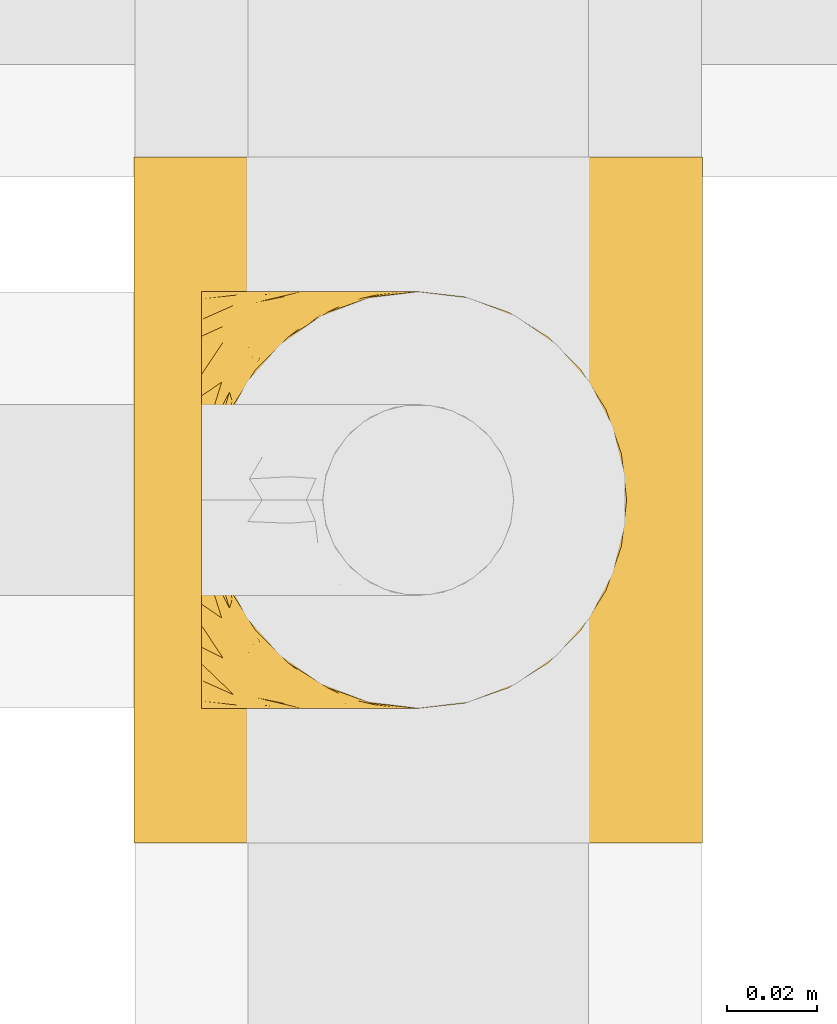
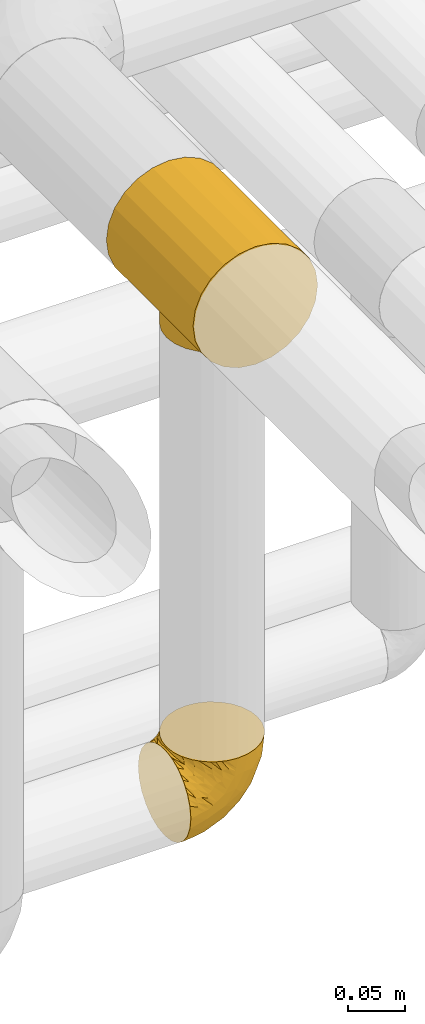
# One storey, part 350 of 827: 2 coverings.
"""IFC2X3 building model written with IfcOpenShell, lengths in millimetres."""

from ifc_helpers import new_model, entity, si_unit, converted_unit, derived_unit, direction, frame, origin, place, context, subcontext, project, spatial, faceted_brep, element, save


model = new_model("IFC2X3")

# Units and contexts
model_context = context("Model", 3, precision=0.01, world=origin(), true_north=direction((6.12303176911189e-17, 1.0)))
body_context = subcontext(model_context, "Body", "Model", "MODEL_VIEW")
ifc_project = project(units=[si_unit("LENGTHUNIT", "METRE", prefix="MILLI"), si_unit("AREAUNIT", "SQUARE_METRE"), si_unit("VOLUMEUNIT", "CUBIC_METRE"), converted_unit("PLANEANGLEUNIT", "DEGREE", entity("IfcRatioMeasure", 0.0174532925199433), si_unit("PLANEANGLEUNIT", "RADIAN"), dimensions=[0, 0, 0, 0, 0, 0, 0]), si_unit("MASSUNIT", "GRAM", prefix="KILO"), derived_unit("MASSDENSITYUNIT", [(si_unit("MASSUNIT", "GRAM", prefix="KILO"), 1), (si_unit("LENGTHUNIT", "METRE"), -3)]), derived_unit("MOMENTOFINERTIAUNIT", [(si_unit("LENGTHUNIT", "METRE"), 4)]), si_unit("TIMEUNIT", "SECOND"), si_unit("FREQUENCYUNIT", "HERTZ"), si_unit("THERMODYNAMICTEMPERATUREUNIT", "DEGREE_CELSIUS"), derived_unit("THERMALTRANSMITTANCEUNIT", [(si_unit("MASSUNIT", "GRAM", prefix="KILO"), 1), (si_unit("THERMODYNAMICTEMPERATUREUNIT", "KELVIN"), -1), (si_unit("TIMEUNIT", "SECOND"), -3)]), derived_unit("VOLUMETRICFLOWRATEUNIT", [(si_unit("LENGTHUNIT", "METRE"), 3), (si_unit("TIMEUNIT", "SECOND"), -1)]), derived_unit("MASSFLOWRATEUNIT", [(si_unit("MASSUNIT", "GRAM", prefix="KILO"), 1), (si_unit("TIMEUNIT", "SECOND"), -1)]), derived_unit("ROTATIONALFREQUENCYUNIT", [(si_unit("TIMEUNIT", "SECOND"), -1)]), si_unit("ELECTRICCURRENTUNIT", "AMPERE"), si_unit("ELECTRICVOLTAGEUNIT", "VOLT"), si_unit("POWERUNIT", "WATT"), si_unit("FORCEUNIT", "NEWTON", prefix="KILO"), si_unit("ILLUMINANCEUNIT", "LUX"), si_unit("LUMINOUSFLUXUNIT", "LUMEN"), si_unit("LUMINOUSINTENSITYUNIT", "CANDELA"), derived_unit("USERDEFINED", [(si_unit("MASSUNIT", "GRAM", prefix="KILO"), -1), (si_unit("LENGTHUNIT", "METRE"), -2), (si_unit("TIMEUNIT", "SECOND"), 3), (si_unit("LUMINOUSFLUXUNIT", "LUMEN"), 1)]), derived_unit("LINEARVELOCITYUNIT", [(si_unit("LENGTHUNIT", "METRE"), 1), (si_unit("TIMEUNIT", "SECOND"), -1)]), si_unit("PRESSUREUNIT", "PASCAL"), derived_unit("USERDEFINED", [(si_unit("LENGTHUNIT", "METRE"), -2), (si_unit("MASSUNIT", "GRAM", prefix="KILO"), 1), (si_unit("TIMEUNIT", "SECOND"), -2)]), derived_unit("LINEARFORCEUNIT", [(si_unit("MASSUNIT", "GRAM", prefix="KILO"), 1), (si_unit("LENGTHUNIT", "METRE"), 1), (si_unit("TIMEUNIT", "SECOND"), -2), (si_unit("LENGTHUNIT", "METRE"), -1)]), derived_unit("PLANARFORCEUNIT", [(si_unit("MASSUNIT", "GRAM", prefix="KILO"), 1), (si_unit("LENGTHUNIT", "METRE"), 1), (si_unit("TIMEUNIT", "SECOND"), -2), (si_unit("LENGTHUNIT", "METRE"), -2)])], contexts=[model_context])

# Site, building, storey
site_placement = place(None, origin())
site = spatial("IfcSite", under=ifc_project, at=site_placement, CompositionType="ELEMENT")
building_placement = place(site_placement, origin())
building = spatial("IfcBuilding", under=site, at=building_placement, CompositionType="ELEMENT")
storey_placement = place(building_placement, frame((0.0, 0.0, 28200.0)))
storey = spatial("IfcBuildingStorey", under=building, at=storey_placement, Name="08", CompositionType="ELEMENT", Elevation=28200.0)

# Coverings
covering_1_placement = place(storey_placement, frame((36155.39, 18148.95, 3485.35)))
element("IfcCovering", 1, at=covering_1_placement, inside=storey, Name=":ADSK_", ObjectType=":ADSK_", PredefinedType="INSULATION", context=body_context, shape_type="Brep", body=[
    faceted_brep([(33.12, 152.0, 119.25), (48.33, 152.0, 125.55), (64.65, 152.0, 127.7), (80.96, 152.0, 125.55), (96.17, 152.0, 119.25), (109.23, 152.0, 109.23), (119.25, 152.0, 96.17), (125.55, 152.0, 80.96), (127.7, 152.0, 64.65), (125.55, 152.0, 48.33), (119.25, 152.0, 33.12), (109.23, 152.0, 20.06), (102.7, 152.0, 15.05), (96.17, 152.0, 10.04), (88.57, 152.0, 6.89), (80.96, 152.0, 3.74), (72.8, 152.0, 2.67), (64.65, 152.0, 1.6), (56.49, 152.0, 2.67), (48.33, 152.0, 3.74), (40.72, 152.0, 6.89), (33.12, 152.0, 10.04), (26.59, 152.0, 15.05), (20.06, 152.0, 20.06), (10.04, 152.0, 33.12), (3.74, 152.0, 48.33), (1.6, 152.0, 64.65), (3.74, 152.0, 80.96), (10.04, 152.0, 96.17), (20.06, 152.0, 109.23), (127.7, 0.0, 64.65), (125.55, 0.0, 80.96), (119.25, 0.0, 96.17), (109.23, 0.0, 109.23), (96.17, 0.0, 119.25), (80.96, 0.0, 125.55), (64.65, 0.0, 127.7), (48.33, 0.0, 125.55), (33.12, 0.0, 119.25), (20.06, 0.0, 109.23), (10.04, 0.0, 96.17), (3.74, 0.0, 80.96), (1.6, 0.0, 64.65), (3.74, 0.0, 48.33), (10.04, 0.0, 33.12), (20.06, 0.0, 20.06), (26.59, 0.0, 15.05), (33.12, 0.0, 10.04), (40.72, 0.0, 6.89), (48.33, 0.0, 3.74), (56.49, 0.0, 2.67), (64.65, 0.0, 1.6), (72.8, 0.0, 2.67), (80.96, 0.0, 3.74), (88.57, 0.0, 6.89), (96.17, 0.0, 10.04), (102.7, 0.0, 15.05), (109.23, 0.0, 20.06), (119.25, 0.0, 33.12), (125.55, 0.0, 48.33), (106.13, 55.66, 17.16), (100.79, 47.22, 12.98), (85.23, 117.36, 5.05), (109.6, 65.36, 20.44), (110.85, 76.0, 21.74), (109.6, 86.64, 20.44), (70.0, 121.57, 2.05), (68.66, 121.73, 1.94), (67.32, 121.89, 1.82), (65.98, 122.04, 1.71), (64.65, 122.2, 1.6), (64.65, 29.8, 1.6), (65.98, 29.96, 1.71), (67.32, 30.11, 1.82), (68.66, 30.27, 1.94), (70.0, 30.43, 2.05), (106.13, 96.34, 17.16), (100.79, 104.78, 12.98), (85.23, 34.64, 5.05), (89.51, 37.39, 6.89), (93.79, 40.15, 8.73), (80.29, 119.15, 3.78), (77.82, 120.05, 3.15), (75.35, 120.94, 2.51), (75.35, 31.06, 2.51), (72.67, 30.74, 2.28), (77.82, 31.95, 3.15), (80.29, 32.85, 3.78), (93.79, 111.85, 8.73), (89.51, 114.61, 6.89), (72.67, 121.26, 2.28), (59.29, 30.43, 2.05), (53.94, 31.06, 2.51), (35.5, 40.15, 8.73), (39.78, 37.39, 6.89), (44.06, 34.64, 5.05), (49.0, 32.85, 3.78), (51.47, 31.95, 3.15), (56.62, 30.74, 2.28), (59.29, 121.57, 2.05), (56.62, 121.26, 2.28), (53.94, 120.94, 2.51), (63.31, 122.04, 1.71), (61.97, 121.89, 1.82), (60.63, 121.73, 1.94), (60.63, 30.27, 1.94), (61.97, 30.11, 1.82), (63.31, 29.96, 1.71), (35.5, 111.85, 8.73), (44.06, 117.36, 5.05), (28.5, 104.78, 12.98), (51.47, 120.05, 3.15), (49.0, 119.15, 3.78), (28.5, 47.22, 12.98), (23.17, 55.66, 17.16), (19.69, 65.36, 20.44), (18.45, 76.0, 21.74), (23.17, 96.34, 17.16), (19.69, 86.64, 20.44), (39.78, 114.61, 6.89), (110.85, 76.0, 0.65), (109.27, 64.04, 0.65), (104.66, 52.9, 0.65), (97.31, 43.33, 0.65), (87.75, 35.99, 0.65), (82.17, 33.68, 0.65), (79.39, 32.53, 0.65), (76.6, 31.37, 0.65), (75.11, 31.18, 0.65), (73.61, 30.98, 0.65), (72.12, 30.78, 0.65), (70.62, 30.59, 0.65), (69.13, 30.39, 0.65), (67.63, 30.19, 0.65), (66.14, 30.0, 0.65), (64.65, 29.8, 0.65), (63.15, 30.0, 0.65), (61.66, 30.19, 0.65), (60.16, 30.39, 0.65), (58.67, 30.59, 0.65), (57.17, 30.78, 0.65), (55.68, 30.98, 0.65), (54.18, 31.18, 0.65), (52.69, 31.37, 0.65), (49.9, 32.53, 0.65), (47.12, 33.68, 0.65), (41.55, 35.99, 0.65), (31.98, 43.33, 0.65), (24.63, 52.9, 0.65), (20.02, 64.04, 0.65), (18.45, 76.0, 0.65), (20.02, 87.96, 0.65), (24.63, 99.1, 0.65), (31.98, 108.67, 0.65), (41.55, 116.01, 0.65), (47.12, 118.32, 0.65), (49.9, 119.47, 0.65), (52.69, 120.63, 0.65), (54.18, 120.82, 0.65), (55.68, 121.02, 0.65), (57.17, 121.22, 0.65), (58.67, 121.41, 0.65), (60.16, 121.61, 0.65), (61.66, 121.81, 0.65), (63.15, 122.0, 0.65), (64.65, 122.2, 0.65), (66.14, 122.0, 0.65), (67.63, 121.81, 0.65), (69.13, 121.61, 0.65), (70.62, 121.41, 0.65), (72.12, 121.22, 0.65), (73.61, 121.02, 0.65), (75.11, 120.82, 0.65), (76.6, 120.63, 0.65), (79.39, 119.47, 0.65), (82.17, 118.32, 0.65), (87.75, 116.01, 0.65), (97.31, 108.67, 0.65), (104.66, 99.1, 0.65), (109.27, 87.96, 0.65)], [[[0, 1, 2, 3, 4, 5, 6, 7, 8, 9, 10, 11, 12, 13, 14, 15, 16, 17, 18, 19, 20, 21, 22, 23, 24, 25, 26, 27, 28, 29]], [[30, 31, 32, 33, 34, 35, 36, 37, 38, 39, 40, 41, 42, 43, 44, 45, 46, 47, 48, 49, 50, 51, 52, 53, 54, 55, 56, 57, 58, 59]], [[34, 33, 5, 4]], [[2, 36, 35, 3]], [[4, 3, 35, 34]], [[6, 32, 31, 7]], [[7, 31, 30, 8]], [[5, 33, 32, 6]], [[59, 9, 8, 30]], [[58, 10, 9, 59]], [[56, 60, 57]], [[61, 56, 55]], [[62, 15, 14]], [[60, 63, 57]], [[60, 56, 61]], [[58, 57, 64]], [[57, 63, 64]], [[64, 65, 11]], [[17, 66, 67, 68, 69, 70]], [[51, 71, 72, 73, 74, 75]], [[12, 76, 77]], [[76, 11, 65]], [[77, 13, 12]], [[64, 11, 10]], [[64, 10, 58]], [[54, 78, 79, 80]], [[54, 80, 55]], [[78, 54, 53]], [[15, 62, 81, 82, 83]], [[84, 53, 52]], [[51, 75, 52]], [[52, 75, 85, 84]], [[53, 84, 86, 87, 78]], [[77, 88, 13]], [[88, 14, 13]], [[14, 88, 89, 62]], [[16, 83, 90, 66]], [[12, 11, 76]], [[17, 16, 66]], [[16, 15, 83]], [[80, 61, 55]], [[50, 91, 51]], [[92, 50, 49]], [[47, 93, 48]], [[48, 93, 94, 95]], [[95, 49, 48]], [[49, 95, 96, 97, 92]], [[50, 92, 98, 91]], [[18, 99, 100, 101]], [[17, 70, 102, 103, 104, 99]], [[51, 91, 105, 106, 107, 71]], [[108, 21, 20]], [[17, 99, 18]], [[20, 19, 109]], [[21, 108, 110]], [[109, 19, 101, 111, 112]], [[113, 47, 46]], [[113, 93, 47]], [[46, 114, 113]], [[114, 46, 45]], [[114, 45, 115]], [[24, 44, 43, 25]], [[44, 116, 45]], [[45, 116, 115]], [[43, 42, 26, 25]], [[101, 19, 18]], [[117, 118, 23]], [[20, 109, 119, 108]], [[110, 22, 21]], [[22, 117, 23]], [[118, 116, 23]], [[116, 24, 23]], [[116, 44, 24]], [[117, 22, 110]], [[27, 41, 40, 28]], [[28, 40, 39, 29]], [[42, 41, 27, 26]], [[0, 38, 37, 1]], [[1, 37, 36, 2]], [[29, 39, 38, 0]], [[120, 121, 122, 123, 124, 125, 126, 127, 128, 129, 130, 131, 132, 133, 134, 135, 136, 137, 138, 139, 140, 141, 142, 143, 144, 145, 146, 147, 148, 149, 150, 151, 152, 153, 154, 155, 156, 157, 158, 159, 160, 161, 162, 163, 164, 165, 166, 167, 168, 169, 170, 171, 172, 173, 174, 175, 176, 177, 178, 179]], [[84, 129, 128, 127]], [[132, 75, 74]], [[74, 133, 132]], [[78, 125, 124]], [[73, 134, 133]], [[132, 131, 75]], [[127, 86, 84]], [[79, 78, 124]], [[86, 126, 87]], [[123, 79, 124]], [[123, 80, 79]], [[87, 126, 125]], [[61, 123, 122]], [[85, 131, 130, 129]], [[122, 121, 60]], [[129, 84, 85]], [[72, 135, 134]], [[120, 63, 121]], [[125, 78, 87]], [[61, 122, 60]], [[86, 127, 126]], [[63, 60, 121]], [[64, 63, 120]], [[131, 85, 75]], [[123, 61, 80]], [[133, 74, 73]], [[135, 72, 71]], [[134, 73, 72]], [[65, 120, 179]], [[69, 165, 70]], [[90, 171, 170, 169]], [[76, 179, 178]], [[173, 83, 82]], [[64, 120, 65]], [[176, 62, 89]], [[65, 179, 76]], [[178, 77, 76]], [[83, 173, 172, 171]], [[178, 177, 77]], [[167, 67, 168]], [[177, 176, 89]], [[167, 68, 67]], [[175, 174, 81]], [[81, 174, 82]], [[67, 66, 168]], [[169, 66, 90]], [[88, 177, 89]], [[62, 176, 175]], [[171, 90, 83]], [[175, 81, 62]], [[82, 174, 173]], [[166, 69, 68]], [[177, 88, 77]], [[66, 169, 168]], [[68, 167, 166]], [[165, 69, 166]], [[101, 159, 158, 157]], [[162, 99, 104]], [[104, 163, 162]], [[109, 155, 154]], [[103, 164, 163]], [[162, 161, 99]], [[157, 111, 101]], [[119, 109, 154]], [[111, 156, 112]], [[153, 119, 154]], [[153, 108, 119]], [[112, 156, 155]], [[110, 153, 152]], [[100, 161, 160, 159]], [[152, 151, 117]], [[159, 101, 100]], [[102, 165, 164]], [[150, 118, 151]], [[155, 109, 112]], [[110, 152, 117]], [[111, 157, 156]], [[118, 117, 151]], [[116, 118, 150]], [[161, 100, 99]], [[153, 110, 108]], [[163, 104, 103]], [[165, 102, 70]], [[164, 103, 102]], [[115, 150, 149]], [[107, 135, 71]], [[98, 141, 140, 139]], [[114, 149, 148]], [[143, 92, 97]], [[116, 150, 115]], [[146, 95, 94]], [[115, 149, 114]], [[148, 113, 114]], [[92, 143, 142, 141]], [[148, 147, 113]], [[137, 105, 138]], [[147, 146, 94]], [[137, 106, 105]], [[145, 144, 96]], [[96, 144, 97]], [[105, 91, 138]], [[139, 91, 98]], [[93, 147, 94]], [[95, 146, 145]], [[141, 98, 92]], [[145, 96, 95]], [[97, 144, 143]], [[136, 107, 106]], [[147, 93, 113]], [[91, 139, 138]], [[106, 137, 136]], [[135, 107, 136]]]),
])
covering_2_placement = place(storey_placement, frame((36170.44, 18177.15, 2952.11)))
element("IfcCovering", 2, at=covering_2_placement, inside=storey, Name=":ADSK_", ObjectType=":ADSK_", PredefinedType="INSULATION", context=body_context, shape_type="Brep", body=[
    faceted_brep([(78.41, 11.68, 95.8), (85.72, 19.0, 95.8), (91.22, 27.76, 95.8), (94.64, 37.52, 95.8), (95.8, 47.8, 95.8), (94.64, 58.08, 95.8), (91.22, 67.85, 95.8), (85.71, 76.61, 95.8), (78.39, 83.92, 95.8), (69.63, 89.42, 95.8), (59.87, 92.84, 95.8), (49.6, 94.0, 95.8), (45.45, 93.53, 95.8), (42.38, 93.18, 95.8), (39.31, 92.84, 95.8), (34.43, 91.13, 95.8), (29.54, 89.42, 95.8), (25.16, 86.66, 95.8), (20.78, 83.91, 95.8), (17.13, 80.25, 95.8), (13.47, 76.59, 95.8), (7.97, 67.83, 95.8), (6.26, 62.95, 95.8), (4.55, 58.07, 95.8), (3.4, 47.8, 95.8), (4.55, 37.51, 95.8), (6.26, 32.63, 95.8), (7.97, 27.74, 95.8), (13.48, 18.98, 95.8), (17.14, 15.33, 95.8), (20.8, 11.67, 95.8), (25.18, 8.92, 95.8), (29.56, 6.17, 95.8), (34.44, 4.46, 95.8), (39.32, 2.75, 95.8), (42.39, 2.41, 95.8), (45.45, 2.06, 95.8), (49.6, 1.6, 95.8), (59.88, 2.75, 95.8), (69.65, 6.17, 95.8), (1.6, 47.8, 94.0), (1.6, 59.75, 92.42), (1.6, 70.9, 87.81), (1.6, 75.68, 84.13), (1.6, 80.46, 80.46), (1.6, 84.13, 75.68), (1.6, 87.81, 70.9), (1.6, 90.11, 65.32), (1.6, 92.42, 59.75), (1.6, 92.9, 56.14), (1.6, 93.17, 54.06), (1.6, 93.45, 51.97), (1.6, 94.0, 47.8), (1.6, 92.42, 35.84), (1.6, 87.81, 24.7), (1.6, 80.46, 15.13), (1.6, 70.9, 7.78), (1.6, 59.75, 3.17), (1.6, 47.8, 1.6), (1.6, 35.84, 3.17), (1.6, 24.7, 7.78), (1.6, 15.13, 15.13), (1.6, 7.78, 24.7), (1.6, 3.17, 35.84), (1.6, 1.6, 47.8), (1.6, 2.14, 51.97), (1.6, 2.69, 56.14), (1.6, 3.17, 59.75), (1.6, 5.48, 65.32), (1.6, 7.78, 70.9), (1.6, 11.46, 75.68), (1.6, 15.13, 80.46), (1.6, 19.91, 84.13), (1.6, 24.7, 87.81), (1.6, 35.84, 92.42), (36.81, 23.61, 15.84), (23.28, 31.99, 6.99), (45.8, 35.87, 14.39), (30.7, 47.8, 6.21), (21.2, 40.43, 4.26), (12.96, 47.8, 3.39), (66.19, 31.83, 31.2), (54.51, 23.37, 26.47), (17.98, 21.41, 11.44), (36.69, 3.07, 47.66), (35.54, 1.6, 61.85), (31.64, 1.6, 59.25), (27.75, 1.6, 56.65), (23.86, 1.6, 54.05), (19.96, 1.6, 51.45), (22.8, 13.45, 19.8), (42.67, 15.25, 26.22), (33.21, 8.07, 31.58), (59.45, 16.0, 38.36), (71.5, 17.34, 51.54), (62.66, 10.58, 51.6), (54.5, 5.34, 55.97), (47.57, 2.39, 62.88), (48.81, 8.36, 41.35), (74.98, 10.04, 82.24), (18.7, 2.59, 40.88), (15.75, 6.28, 29.0), (91.17, 34.28, 74.06), (85.28, 38.73, 54.53), (82.58, 27.25, 57.98), (75.78, 29.88, 43.81), (74.98, 38.6, 38.22), (67.27, 23.44, 38.33), (87.38, 25.25, 74.76), (82.04, 17.23, 76.85), (94.0, 47.8, 84.43), (77.8, 47.8, 40.43), (67.38, 47.8, 30.01), (56.2, 2.53, 78.67), (48.85, 1.6, 92.06), (48.11, 1.6, 88.32), (47.57, 1.6, 85.6), (47.03, 1.6, 82.88), (46.48, 1.6, 80.15), (45.94, 1.6, 77.43), (65.78, 5.71, 76.36), (17.24, 1.6, 50.91), (14.51, 1.6, 50.37), (11.79, 1.6, 49.82), (9.07, 1.6, 49.28), (7.2, 1.6, 48.91), (5.33, 1.6, 48.54), (91.18, 47.8, 66.69), (43.34, 1.6, 73.53), (40.74, 1.6, 69.64), (38.14, 1.6, 65.75), (72.73, 11.89, 66.13), (56.96, 47.8, 19.59), (62.23, 39.69, 24.64), (84.49, 47.8, 53.56), (43.83, 47.8, 12.9), (12.05, 13.84, 82.81), (18.95, 9.16, 81.22), (13.02, 15.79, 86.57), (8.34, 25.75, 92.75), (14.63, 16.09, 89.68), (11.09, 7.51, 72.26), (13.66, 3.99, 64.73), (20.08, 2.66, 62.45), (9.61, 3.16, 60.63), (9.48, 2.35, 56.91), (16.1, 2.23, 58.14), (3.42, 38.35, 93.7), (26.63, 6.18, 83.4), (33.72, 2.7, 75.54), (34.77, 2.93, 79.46), (6.75, 16.01, 82.28), (13.31, 9.08, 76.25), (21.11, 9.3, 84.69), (19.94, 11.68, 90.18), (8.67, 4.65, 65.12), (26.11, 3.65, 71.71), (29.3, 3.61, 75.21), (6.32, 12.8, 78.6), (39.92, 2.43, 87.27), (27.05, 6.83, 87.92), (6.04, 21.65, 86.94), (34.4, 3.7, 86.1), (2.87, 47.8, 94.52), (20.92, 3.37, 66.23), (27.43, 7.03, 91.08), (7.54, 7.87, 71.77), (18.45, 7.26, 76.21), (23.88, 3.41, 68.59), (7.77, 23.81, 89.94), (13.3, 86.5, 76.25), (11.09, 88.08, 72.26), (6.33, 82.79, 78.6), (9.07, 94.0, 49.28), (5.33, 94.0, 48.54), (14.51, 94.0, 50.37), (11.79, 94.0, 49.82), (3.42, 57.24, 93.7), (7.76, 71.76, 89.95), (47.03, 94.0, 82.88), (47.57, 94.0, 85.6), (48.85, 94.0, 92.06), (48.11, 94.0, 88.32), (14.62, 79.49, 89.68), (27.03, 88.75, 87.92), (20.08, 92.93, 62.45), (20.92, 92.22, 66.24), (27.75, 94.0, 56.65), (31.64, 94.0, 59.25), (9.61, 92.43, 60.63), (9.48, 93.24, 56.91), (8.33, 69.82, 92.76), (6.74, 79.57, 82.28), (12.04, 81.74, 82.81), (23.86, 94.0, 54.05), (19.96, 94.0, 51.45), (16.1, 93.36, 58.14), (19.93, 83.9, 90.18), (21.1, 86.28, 84.7), (39.92, 93.16, 87.25), (33.68, 92.88, 75.58), (29.28, 91.98, 75.2), (26.62, 89.41, 83.39), (26.08, 91.93, 71.7), (18.93, 86.42, 81.22), (27.87, 88.82, 90.73), (34.75, 92.66, 79.47), (6.04, 73.93, 86.94), (38.14, 94.0, 65.75), (12.79, 79.5, 86.75), (34.41, 91.89, 86.08), (45.94, 94.0, 77.43), (43.34, 94.0, 73.53), (40.74, 94.0, 69.64), (13.66, 91.6, 64.73), (17.24, 94.0, 50.91), (8.67, 90.94, 65.12), (35.54, 94.0, 61.85), (23.83, 92.16, 68.62), (18.43, 88.32, 76.22), (6.03, 86.13, 74.03), (46.48, 94.0, 80.15), (34.52, 93.2, 49.81), (21.2, 55.16, 4.26), (23.82, 82.02, 19.95), (41.32, 84.29, 30.61), (47.62, 76.94, 25.71), (52.66, 68.33, 22.43), (36.81, 71.98, 15.85), (49.75, 92.52, 60.69), (19.07, 92.9, 40.49), (45.8, 59.72, 14.39), (23.28, 63.6, 6.99), (21.35, 88.89, 29.56), (17.98, 74.18, 11.45), (82.57, 68.35, 57.98), (91.17, 61.33, 74.06), (85.27, 56.86, 54.52), (73.89, 68.62, 43.47), (66.19, 63.76, 31.2), (62.43, 72.19, 33.27), (63.53, 88.69, 64.26), (58.45, 92.19, 74.29), (67.16, 89.75, 80.41), (62.22, 55.9, 24.64), (81.54, 77.99, 73.62), (74.8, 85.21, 78.98), (75.83, 74.99, 53.69), (41.45, 90.23, 42.86), (76.72, 59.86, 41.67), (88.2, 70.75, 79.66), (71.6, 81.72, 58.41), (56.23, 86.53, 47.11), (59.44, 79.6, 38.37)], [[[0, 1, 2, 3, 4, 5, 6, 7, 8, 9, 10, 11, 12, 13, 14, 15, 16, 17, 18, 19, 20, 21, 22, 23, 24, 25, 26, 27, 28, 29, 30, 31, 32, 33, 34, 35, 36, 37, 38, 39]], [[40, 41, 42, 43, 44, 45, 46, 47, 48, 49, 50, 51, 52, 53, 54, 55, 56, 57, 58, 59, 60, 61, 62, 63, 64, 65, 66, 67, 68, 69, 70, 71, 72, 73, 74]], [[75, 76, 77]], [[78, 79, 80]], [[77, 81, 82]], [[76, 75, 83]], [[84, 85, 86, 87, 88, 89]], [[90, 91, 92]], [[76, 60, 59]], [[93, 94, 95]], [[90, 62, 61]], [[83, 61, 60]], [[96, 97, 84]], [[98, 93, 95]], [[0, 39, 99]], [[100, 84, 89]], [[62, 101, 63]], [[2, 102, 3]], [[92, 84, 100]], [[103, 102, 104]], [[103, 105, 106]], [[93, 107, 94]], [[1, 108, 2]], [[92, 101, 90]], [[108, 1, 109]], [[102, 110, 3]], [[93, 82, 107]], [[102, 108, 104]], [[111, 106, 112]], [[109, 0, 99]], [[113, 37, 114, 115, 116, 117, 118, 119]], [[120, 38, 113]], [[100, 89, 121, 122, 123, 124, 125, 126, 64]], [[127, 102, 103]], [[97, 119, 128, 129, 130, 85]], [[99, 120, 131]], [[132, 133, 77]], [[59, 80, 79]], [[1, 0, 109]], [[98, 84, 92]], [[94, 109, 131]], [[120, 39, 38]], [[93, 91, 82]], [[104, 94, 105]], [[97, 113, 119]], [[95, 120, 96]], [[83, 90, 61]], [[91, 93, 98]], [[64, 63, 100]], [[100, 63, 101]], [[77, 76, 79]], [[133, 106, 81]], [[84, 97, 85]], [[113, 96, 120]], [[113, 97, 96]], [[37, 113, 38]], [[110, 102, 127]], [[110, 4, 3]], [[103, 111, 134, 127]], [[90, 75, 91]], [[82, 81, 107]], [[91, 75, 82]], [[77, 82, 75]], [[76, 83, 60]], [[90, 83, 75]], [[105, 107, 81]], [[94, 131, 95]], [[105, 94, 107]], [[109, 94, 104]], [[120, 95, 131]], [[98, 95, 96]], [[84, 98, 96]], [[98, 92, 91]], [[106, 105, 81]], [[103, 104, 105]], [[112, 106, 133]], [[103, 106, 111]], [[112, 133, 132]], [[81, 77, 133]], [[77, 78, 135, 132]], [[120, 99, 39]], [[109, 99, 131]], [[59, 58, 80]], [[59, 79, 76]], [[90, 101, 62]], [[100, 101, 92]], [[2, 108, 102]], [[109, 104, 108]], [[78, 77, 79]], [[136, 137, 138]], [[27, 139, 140]], [[141, 142, 143]], [[144, 145, 121]], [[146, 89, 88]], [[147, 139, 25]], [[148, 149, 150]], [[136, 151, 152]], [[147, 40, 74]], [[24, 147, 25]], [[140, 153, 154]], [[33, 116, 34]], [[73, 72, 151]], [[114, 37, 36, 35, 34, 116, 115]], [[146, 155, 144]], [[156, 85, 130]], [[157, 149, 148]], [[151, 158, 152]], [[117, 33, 159]], [[29, 154, 160]], [[161, 74, 73]], [[162, 128, 119]], [[66, 65, 64, 126, 125, 124, 123, 122, 67]], [[163, 147, 24]], [[27, 140, 28]], [[149, 129, 150]], [[139, 27, 26, 25]], [[68, 144, 69]], [[129, 128, 150]], [[164, 87, 86]], [[130, 129, 149]], [[122, 145, 67]], [[154, 153, 148]], [[162, 119, 159]], [[165, 30, 160]], [[150, 160, 148]], [[128, 162, 150]], [[30, 165, 31]], [[145, 144, 68]], [[89, 146, 144]], [[87, 164, 143]], [[166, 155, 142]], [[88, 87, 143]], [[162, 160, 150]], [[160, 30, 29]], [[154, 29, 28]], [[140, 154, 28]], [[160, 154, 148]], [[140, 137, 153]], [[157, 148, 153]], [[156, 130, 157]], [[153, 137, 157]], [[157, 137, 156]], [[167, 137, 136]], [[168, 85, 156]], [[152, 168, 167]], [[167, 168, 156]], [[164, 152, 141]], [[71, 158, 72]], [[152, 167, 136]], [[88, 142, 146]], [[144, 155, 69]], [[146, 142, 155]], [[70, 166, 71]], [[142, 141, 166]], [[70, 69, 155]], [[141, 158, 71]], [[161, 73, 151]], [[138, 137, 140]], [[161, 136, 169]], [[136, 161, 151]], [[74, 161, 169]], [[152, 158, 141]], [[151, 72, 158]], [[168, 152, 164]], [[137, 167, 156]], [[164, 86, 168]], [[85, 168, 86]], [[116, 33, 117]], [[130, 149, 157]], [[67, 145, 68]], [[121, 89, 144]], [[145, 122, 121]], [[40, 147, 163]], [[169, 147, 74]], [[159, 33, 32]], [[162, 159, 32]], [[159, 119, 118, 117]], [[139, 147, 169]], [[139, 169, 138]], [[162, 32, 31]], [[141, 143, 164]], [[88, 143, 142]], [[71, 166, 141]], [[155, 166, 70]], [[139, 138, 140]], [[169, 136, 138]], [[160, 162, 165]], [[162, 31, 165]], [[170, 171, 172]], [[173, 174, 52, 51, 50, 49, 48, 175, 176]], [[177, 178, 41]], [[179, 15, 180]], [[12, 11, 181, 182, 180, 14, 13]], [[183, 21, 20]], [[19, 18, 184]], [[185, 186, 187]], [[186, 188, 187]], [[43, 172, 44]], [[189, 190, 47]], [[23, 22, 21, 191]], [[170, 192, 193]], [[40, 163, 177]], [[194, 195, 196]], [[24, 23, 177]], [[197, 198, 183]], [[199, 15, 179]], [[47, 46, 189]], [[200, 201, 202]], [[201, 203, 204]], [[205, 206, 184]], [[207, 41, 178]], [[16, 15, 199]], [[14, 180, 15]], [[202, 201, 198]], [[208, 201, 200]], [[163, 24, 177]], [[48, 47, 190]], [[196, 195, 189]], [[197, 184, 202]], [[204, 193, 209]], [[210, 211, 212]], [[206, 212, 213]], [[205, 17, 210]], [[184, 206, 202]], [[210, 212, 206]], [[185, 194, 214]], [[189, 215, 190]], [[216, 45, 214]], [[186, 171, 170]], [[189, 216, 196]], [[197, 20, 19]], [[194, 185, 187]], [[197, 183, 20]], [[184, 197, 19]], [[197, 202, 198]], [[206, 200, 202]], [[204, 183, 198]], [[201, 208, 203]], [[203, 208, 217]], [[204, 198, 201]], [[217, 188, 218]], [[193, 219, 170]], [[171, 186, 185]], [[170, 218, 186]], [[170, 219, 218]], [[42, 207, 192]], [[171, 220, 172]], [[216, 189, 46]], [[214, 194, 196]], [[44, 220, 45]], [[214, 196, 216]], [[216, 46, 45]], [[214, 45, 220]], [[192, 43, 42]], [[204, 203, 219]], [[207, 193, 192]], [[209, 193, 178]], [[41, 207, 42]], [[193, 207, 178]], [[43, 192, 172]], [[170, 172, 192]], [[204, 219, 193]], [[219, 203, 218]], [[217, 218, 203]], [[188, 186, 218]], [[206, 213, 200]], [[208, 200, 213]], [[199, 210, 16]], [[215, 189, 195]], [[215, 175, 190]], [[175, 48, 190]], [[199, 179, 221, 211]], [[210, 199, 211]], [[23, 191, 177]], [[40, 177, 41]], [[178, 177, 191]], [[21, 183, 191]], [[209, 191, 183]], [[205, 18, 17]], [[17, 16, 210]], [[171, 185, 214]], [[172, 220, 44]], [[214, 220, 171]], [[191, 209, 178]], [[204, 209, 183]], [[206, 205, 210]], [[18, 205, 184]], [[222, 195, 194, 187, 188, 217]], [[57, 223, 80]], [[224, 225, 226]], [[226, 227, 228]], [[229, 217, 208, 213, 212, 211]], [[230, 52, 174, 173, 176, 175, 215, 195]], [[231, 232, 228]], [[231, 78, 223]], [[223, 57, 232]], [[224, 233, 225]], [[233, 54, 53]], [[234, 232, 56]], [[56, 55, 234]], [[234, 224, 228]], [[235, 236, 237]], [[224, 55, 54]], [[238, 239, 240]], [[52, 230, 53]], [[241, 242, 243]], [[227, 244, 231]], [[11, 10, 242]], [[236, 6, 5]], [[7, 245, 8]], [[8, 246, 9]], [[238, 247, 235]], [[222, 229, 248]], [[242, 211, 221, 179, 180, 182, 181, 11]], [[233, 53, 230]], [[111, 112, 249]], [[250, 6, 236]], [[246, 251, 241]], [[6, 250, 7]], [[127, 236, 110]], [[248, 229, 252]], [[246, 8, 245]], [[235, 245, 250]], [[236, 5, 110]], [[235, 249, 238]], [[237, 236, 127]], [[243, 9, 246]], [[252, 229, 241]], [[56, 232, 57]], [[222, 230, 195]], [[225, 248, 252]], [[248, 233, 230]], [[54, 233, 224]], [[231, 228, 227]], [[244, 132, 231]], [[248, 225, 233]], [[226, 225, 253]], [[235, 250, 236]], [[245, 7, 250]], [[251, 246, 245]], [[243, 246, 241]], [[247, 245, 235]], [[252, 251, 253]], [[229, 222, 217]], [[230, 222, 248]], [[5, 4, 110]], [[237, 127, 134, 111]], [[238, 249, 239]], [[224, 234, 55]], [[232, 234, 228]], [[242, 241, 229]], [[10, 9, 243]], [[211, 242, 229]], [[10, 243, 242]], [[80, 223, 78]], [[80, 58, 57]], [[231, 223, 232]], [[227, 240, 239]], [[224, 226, 228]], [[240, 226, 253]], [[227, 239, 244]], [[226, 240, 227]], [[251, 247, 253]], [[240, 253, 247]], [[249, 235, 237]], [[237, 111, 249]], [[112, 132, 244]], [[112, 244, 249]], [[78, 231, 132, 135]], [[249, 244, 239]], [[247, 238, 240]], [[245, 247, 251]], [[251, 252, 241]], [[225, 252, 253]]]),
])

save(model, "model.ifc")
